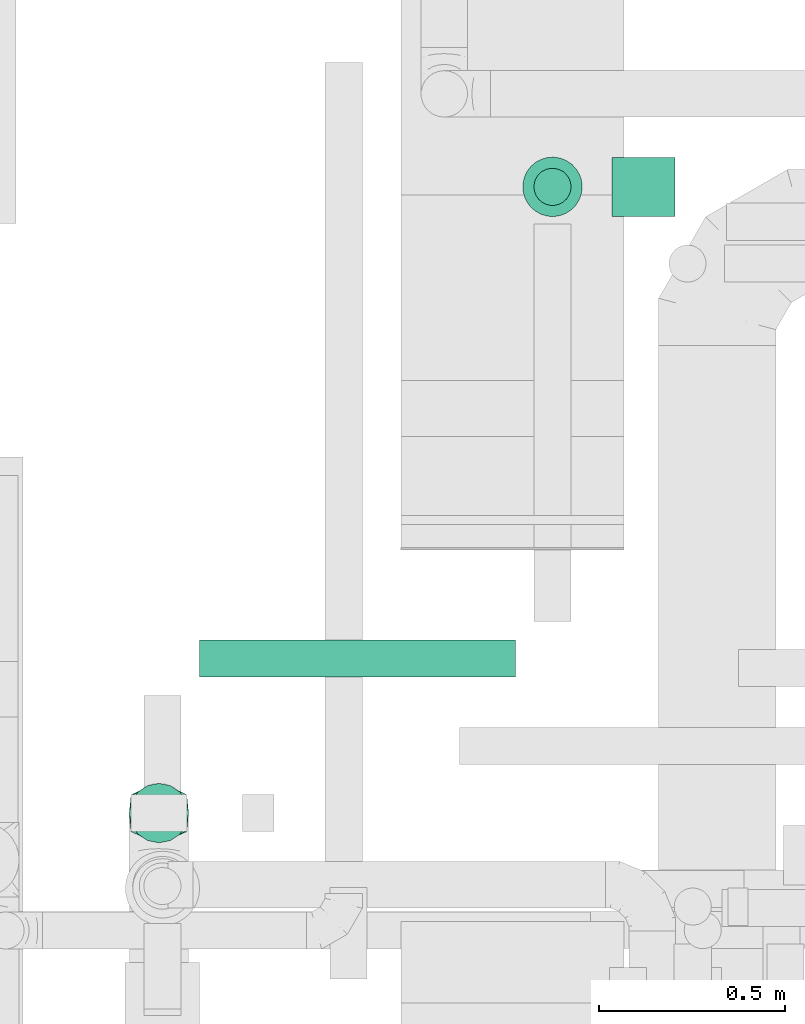
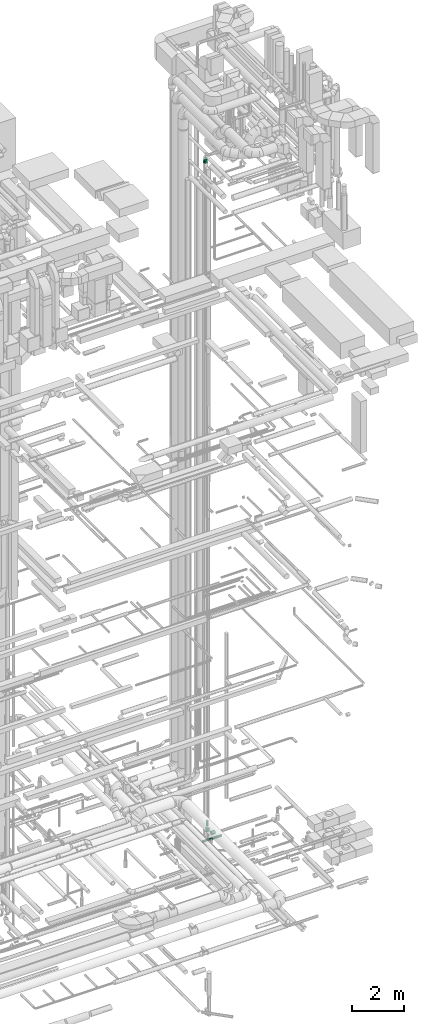
# One storey, part 272 of 337: 4 flow segments, 1 flow fitting.
"""IFC2X3 building model written with IfcOpenShell, lengths in millimetres."""

import ifcopenshell
import ifcopenshell.guid

model = None  # the IFC model being written
_history = None  # IfcOwnerHistory: only IFC2X3 demands one
_inside = {}  # id of a spatial element -> (the spatial element, [elements in it])
_under = {}  # id of a project, library or spatial element -> (it, [spatial elements below it])
_declared = {}  # id of a project -> (the project, [libraries it declares])
_typed = {}  # id of a type object -> (the type object, [elements of that type])
_made_of = {}  # id of a material, layer set ... -> (it, [elements and type objects made of it])


def new_model(schema):
    """Start an empty IFC model of exactly this schema.

    Asked for "IFC4X3", IfcOpenShell would pick the latest addendum, in which some entities
    have other attributes; the version numbers below select the first issue.
    IFC2X3 requires an IfcOwnerHistory on every rooted entity: one is made here for all.
    """
    global model, _history
    if schema == "IFC4X3":
        model = ifcopenshell.file(schema_version=(4, 3, 0, 0))
    else:
        model = ifcopenshell.file(schema=schema)
    _inside.clear()
    _under.clear()
    _declared.clear()
    _typed.clear()
    _made_of.clear()
    _history = None
    if model.schema == "IFC2X3":
        org = make("IfcOrganization", Name="unknown")
        user = make(
            "IfcPersonAndOrganization",
            ThePerson=make("IfcPerson", FamilyName="unknown"),
            TheOrganization=org,
        )
        app = make(
            "IfcApplication",
            ApplicationDeveloper=org,
            Version="unknown",
            ApplicationFullName="unknown",
            ApplicationIdentifier="unknown",
        )
        _history = make(
            "IfcOwnerHistory",
            OwningUser=user,
            OwningApplication=app,
            ChangeAction="ADDED",
            CreationDate=0,
        )
    return model


def make(cls, **values):
    """One entity of the class cls with the attributes given. An attribute that is None is left unset."""
    return model.create_entity(
        cls, **{name: value for name, value in values.items() if value is not None}
    )


def entity(cls, *values):
    """Any entity or typed value of the class cls, its attributes in the order of the schema. None: left unset."""
    e = model.create_entity(cls)
    for i, value in enumerate(values):
        if value is not None:
            e[i] = value
    return e


def rooted(cls, **values):
    """An entity with a GlobalId (a new one), such as an element, a storey or a relation."""
    return make(cls, GlobalId=ifcopenshell.guid.new(), OwnerHistory=_history, **values)


def si_unit(unit_type, name, prefix=None):
    """IfcSIUnit, for example si_unit("LENGTHUNIT", "METRE", prefix="MILLI")."""
    return make("IfcSIUnit", UnitType=unit_type, Prefix=prefix, Name=name)


def converted_unit(unit_type, name, factor, base, dimensions=None, offset=None):
    """IfcConversionBasedUnit, such as the inch: factor (a typed value) times the base unit."""
    return make(
        "IfcConversionBasedUnit"
        if offset is None
        else "IfcConversionBasedUnitWithOffset",
        ConversionOffset=offset,
        Dimensions=None
        if dimensions is None
        else entity("IfcDimensionalExponents", *dimensions),
        UnitType=unit_type,
        Name=name,
        ConversionFactor=make(
            "IfcMeasureWithUnit", ValueComponent=factor, UnitComponent=base
        ),
    )


def derived_unit(unit_type, elements):
    """IfcDerivedUnit: a product of units, each with its exponent."""
    return make(
        "IfcDerivedUnit",
        Elements=[
            make("IfcDerivedUnitElement", Unit=unit, Exponent=power)
            for unit, power in elements
        ],
        UnitType=unit_type,
    )


def assignment(units):
    """IfcUnitAssignment: the units of a project."""
    return None if units is None else make("IfcUnitAssignment", Units=units)


def point(xyz):
    """IfcCartesianPoint."""
    return None if xyz is None else make("IfcCartesianPoint", Coordinates=xyz)


def direction(xyz):
    """IfcDirection."""
    return None if xyz is None else make("IfcDirection", DirectionRatios=xyz)


def frame(location, z_axis=None, x_axis=None):
    """IfcAxis2Placement3D, a coordinate frame: its origin and axes. An axis left out is left unset."""
    return make(
        "IfcAxis2Placement3D",
        Location=point(location),
        Axis=direction(z_axis),
        RefDirection=direction(x_axis),
    )


def frame_2d(location, x_axis=None):
    """IfcAxis2Placement2D, a coordinate frame in the plane: its origin and x axis."""
    return make(
        "IfcAxis2Placement2D", Location=point(location), RefDirection=direction(x_axis)
    )


def origin():
    """The frame at (0, 0, 0) with its axes left unset."""
    return frame((0.0, 0.0, 0.0))


def origin_2d_with_axis():
    """The frame at (0, 0) in the plane with the x axis (1, 0) written out."""
    return frame_2d((0.0, 0.0), x_axis=(1.0, 0.0))


def place(relative_to, where):
    """IfcLocalPlacement: puts the frame where relative to a parent placement (None: the world)."""
    return make(
        "IfcLocalPlacement", PlacementRelTo=relative_to, RelativePlacement=where
    )


def context(
    kind, dimensions, precision=None, world=None, true_north=None, identifier=None
):
    """IfcGeometricRepresentationContext, for example the 3D "Model" context."""
    return make(
        "IfcGeometricRepresentationContext",
        ContextIdentifier=identifier,
        ContextType=kind,
        CoordinateSpaceDimension=dimensions,
        Precision=precision,
        WorldCoordinateSystem=world,
        TrueNorth=true_north,
    )


def subcontext(parent, identifier, kind, view, scale=None):
    """IfcGeometricRepresentationSubContext, for example "Body" below "Model"."""
    return make(
        "IfcGeometricRepresentationSubContext",
        ContextIdentifier=identifier,
        ContextType=kind,
        ParentContext=parent,
        TargetScale=scale,
        TargetView=view,
    )


def project(units=None, contexts=None):
    """IfcProject with its units and contexts."""
    return rooted(
        "IfcProject",
        Name="project",
        RepresentationContexts=contexts,
        UnitsInContext=assignment(units),
    )


def spatial(cls, under=None, at=None, **own):
    """A site, building, storey or space (cls), placed at a placement, below another one or the project."""
    s = rooted(cls, ObjectPlacement=at, **own)
    if under is not None:
        _under.setdefault(under.id(), (under, []))[1].append(s)
    return s


def profile(cls, at=None, kind="AREA", **sizes):
    """A parametric profile (cls). Its sizes go by their IFC names, for example OverallWidth=200.0."""
    return make(cls, ProfileType=kind, Position=at, **sizes)


def circle(**sizes):
    """IfcCircleProfileDef."""
    return profile("IfcCircleProfileDef", **sizes)


def extrude(swept, where, along, depth):
    """IfcExtrudedAreaSolid: the profile swept, set in the frame where, extruded along a direction by depth."""
    return make(
        "IfcExtrudedAreaSolid",
        SweptArea=swept,
        Position=where,
        ExtrudedDirection=direction(along),
        Depth=depth,
    )


def faces_of(points, faces, orient=None, outer=None):
    """IfcFace entities. A face is a list of loops; a loop is a list of indices into points, from 0.

    orient and outer hold one flag for each loop. By default every Orientation is true, the
    first loop of a face is its IfcFaceOuterBound and the others are IfcFaceBound.
    """
    made = []
    for i, loops in enumerate(faces):
        bounds = []
        for j, loop in enumerate(loops):
            is_outer = j == 0 if outer is None else outer[i][j]
            bounds.append(
                make(
                    "IfcFaceOuterBound" if is_outer else "IfcFaceBound",
                    Bound=make("IfcPolyLoop", Polygon=[points[k] for k in loop]),
                    Orientation=True if orient is None else orient[i][j],
                )
            )
        made.append(make("IfcFace", Bounds=bounds))
    return made


def faceted_brep(points, faces, orient=None, outer=None, voids=None):
    """IfcFacetedBrep: a solid bounded by flat faces; with voids (closed shells), ...WithVoids."""
    shared = [point(p) for p in points]
    hull = make("IfcClosedShell", CfsFaces=faces_of(shared, faces, orient, outer))
    if voids is None:
        return make("IfcFacetedBrep", Outer=hull)
    return make(
        "IfcFacetedBrepWithVoids",
        Outer=hull,
        Voids=[
            make(cls, CfsFaces=faces_of(shared, fs, o, b)) for cls, fs, o, b in voids
        ],
    )


def shape(context_of_items, identifier, shape_type, items):
    """IfcShapeRepresentation: the items that make up one representation, for example the "Body"."""
    return make(
        "IfcShapeRepresentation",
        ContextOfItems=context_of_items,
        RepresentationIdentifier=identifier,
        RepresentationType=shape_type,
        Items=items,
    )


def source(mapping_origin, context_of_items, identifier, shape_type, items):
    """IfcRepresentationMap: a shape defined once, which mapped items show again and again."""
    return make(
        "IfcRepresentationMap",
        MappingOrigin=mapping_origin,
        MappedRepresentation=shape(context_of_items, identifier, shape_type, items),
    )


def transform(
    local_origin,
    x_axis=None,
    y_axis=None,
    z_axis=None,
    scale=None,
    scale2=None,
    scale3=None,
    uniform=True,
):
    """IfcCartesianTransformationOperator3D, or its non-uniform kind. x_axis, y_axis, z_axis: its Axis1, 2, 3."""
    if uniform:
        return make(
            "IfcCartesianTransformationOperator3D",
            Axis1=direction(x_axis),
            Axis2=direction(y_axis),
            LocalOrigin=point(local_origin),
            Scale=scale,
            Axis3=direction(z_axis),
        )
    return make(
        "IfcCartesianTransformationOperator3DnonUniform",
        Axis1=direction(x_axis),
        Axis2=direction(y_axis),
        LocalOrigin=point(local_origin),
        Scale=scale,
        Axis3=direction(z_axis),
        Scale2=scale2,
        Scale3=scale3,
    )


def mapped(mapping_source, mapping_target):
    """IfcMappedItem: shows the shape of a source again, moved by a transform."""
    return make(
        "IfcMappedItem", MappingSource=mapping_source, MappingTarget=mapping_target
    )


def material(Name=None, Category=None):
    """IfcMaterial."""
    return make("IfcMaterial", Name=Name, Category=Category)


def made_of(thing, what):
    """Note that an element or type object is made of a material, layer set ...; save() writes the relation."""
    if what is not None:
        _made_of.setdefault(what.id(), (what, []))[1].append(thing)
    return thing


def type_object(cls, material=None, **own):
    """A type object (cls), such as IfcWallType, which elements share."""
    return made_of(rooted(cls, **own), material)


def type_shapes(of_type, sources):
    """Give a type object the sources (RepresentationMaps) that its elements show as mapped items."""
    of_type.RepresentationMaps = sources


def element(
    cls,
    number,
    at=None,
    inside=None,
    cuts=None,
    type_object=None,
    material=None,
    context=None,
    identifier="Body",
    shape_type=None,
    held_by="IfcProductDefinitionShape",
    body=None,
    shapes=None,
    **own,
):
    """One element of the class cls, such as IfcWall. Its Tag is "e" and its number.

    at: its placement. inside: the storey or other place that contains it. cuts: it is an
    opening in that element (IfcRelVoidsElement). A single representation is given by context,
    identifier, shape_type and body (its items); several are given by shapes. held_by: the class
    of the entity that holds the representations. save() writes the other relations.
    """
    e = rooted(cls, Tag="e%d" % number, ObjectPlacement=at, **own)
    if body is not None:
        shapes = [shape(context, identifier, shape_type, body)]
    if shapes is not None:
        e.Representation = make(held_by, Representations=shapes)
    if inside is not None:
        _inside.setdefault(inside.id(), (inside, []))[1].append(e)
    if cuts is not None:
        rooted(
            "IfcRelVoidsElement", RelatingBuildingElement=cuts, RelatedOpeningElement=e
        )
    if type_object is not None:
        _typed.setdefault(type_object.id(), (type_object, []))[1].append(e)
    return made_of(e, material)


def aggregate(whole, parts):
    """IfcRelAggregates: a whole, such as a stair, and the parts it consists of."""
    return rooted("IfcRelAggregates", RelatingObject=whole, RelatedObjects=parts)


def save(model, path):
    """Write the relations noted so far, then the file.

    IfcRelAggregates (storeys below a building ...), IfcRelContainedInSpatialStructure (elements
    in a storey), IfcRelDefinesByType, IfcRelAssociatesMaterial and IfcRelDeclares: one each for
    every whole, place, type object, material and project.
    """
    for whole, parts in _under.values():
        aggregate(whole, parts)
    for where, things in _inside.values():
        rooted(
            "IfcRelContainedInSpatialStructure",
            RelatedElements=things,
            RelatingStructure=where,
        )
    for kind, things in _typed.values():
        rooted("IfcRelDefinesByType", RelatedObjects=things, RelatingType=kind)
    for what, things in _made_of.values():
        rooted("IfcRelAssociatesMaterial", RelatedObjects=things, RelatingMaterial=what)
    for by, libraries in _declared.values():
        rooted("IfcRelDeclares", RelatingContext=by, RelatedDefinitions=libraries)
    model.write(path)


model = new_model("IFC2X3")

# Units and contexts
model_context = context("Model", 3, precision=0.01, world=origin(), true_north=direction((6.12303176911189e-17, 1.0)))
body_context = subcontext(model_context, "Body", "Model", "MODEL_VIEW")
ifc_project = project(units=[si_unit("LENGTHUNIT", "METRE", prefix="MILLI"), si_unit("AREAUNIT", "SQUARE_METRE"), si_unit("VOLUMEUNIT", "CUBIC_METRE"), converted_unit("PLANEANGLEUNIT", "DEGREE", entity("IfcRatioMeasure", 0.0174532925199433), si_unit("PLANEANGLEUNIT", "RADIAN"), dimensions=[0, 0, 0, 0, 0, 0, 0]), si_unit("MASSUNIT", "GRAM", prefix="KILO"), derived_unit("MASSDENSITYUNIT", [(si_unit("MASSUNIT", "GRAM", prefix="KILO"), 1), (si_unit("LENGTHUNIT", "METRE"), -3)]), derived_unit("MOMENTOFINERTIAUNIT", [(si_unit("LENGTHUNIT", "METRE"), 4)]), si_unit("TIMEUNIT", "SECOND"), si_unit("FREQUENCYUNIT", "HERTZ"), si_unit("THERMODYNAMICTEMPERATUREUNIT", "DEGREE_CELSIUS"), derived_unit("THERMALTRANSMITTANCEUNIT", [(si_unit("MASSUNIT", "GRAM", prefix="KILO"), 1), (si_unit("THERMODYNAMICTEMPERATUREUNIT", "KELVIN"), -1), (si_unit("TIMEUNIT", "SECOND"), -3)]), derived_unit("VOLUMETRICFLOWRATEUNIT", [(si_unit("LENGTHUNIT", "METRE"), 3), (si_unit("TIMEUNIT", "SECOND"), -1)]), derived_unit("MASSFLOWRATEUNIT", [(si_unit("MASSUNIT", "GRAM", prefix="KILO"), 1), (si_unit("TIMEUNIT", "SECOND"), -1)]), derived_unit("ROTATIONALFREQUENCYUNIT", [(si_unit("TIMEUNIT", "SECOND"), -1)]), si_unit("ELECTRICCURRENTUNIT", "AMPERE"), si_unit("ELECTRICVOLTAGEUNIT", "VOLT"), si_unit("POWERUNIT", "WATT"), si_unit("FORCEUNIT", "NEWTON", prefix="KILO"), si_unit("ILLUMINANCEUNIT", "LUX"), si_unit("LUMINOUSFLUXUNIT", "LUMEN"), si_unit("LUMINOUSINTENSITYUNIT", "CANDELA"), derived_unit("USERDEFINED", [(si_unit("MASSUNIT", "GRAM", prefix="KILO"), -1), (si_unit("LENGTHUNIT", "METRE"), -2), (si_unit("TIMEUNIT", "SECOND"), 3), (si_unit("LUMINOUSFLUXUNIT", "LUMEN"), 1)]), derived_unit("LINEARVELOCITYUNIT", [(si_unit("LENGTHUNIT", "METRE"), 1), (si_unit("TIMEUNIT", "SECOND"), -1)]), si_unit("PRESSUREUNIT", "PASCAL"), derived_unit("USERDEFINED", [(si_unit("LENGTHUNIT", "METRE"), -2), (si_unit("MASSUNIT", "GRAM", prefix="KILO"), 1), (si_unit("TIMEUNIT", "SECOND"), -2)]), derived_unit("LINEARFORCEUNIT", [(si_unit("MASSUNIT", "GRAM", prefix="KILO"), 1), (si_unit("LENGTHUNIT", "METRE"), 1), (si_unit("TIMEUNIT", "SECOND"), -2), (si_unit("LENGTHUNIT", "METRE"), -1)]), derived_unit("PLANARFORCEUNIT", [(si_unit("MASSUNIT", "GRAM", prefix="KILO"), 1), (si_unit("LENGTHUNIT", "METRE"), 1), (si_unit("TIMEUNIT", "SECOND"), -2), (si_unit("LENGTHUNIT", "METRE"), -2)])], contexts=[model_context])

# Site, building, storey
site_placement = place(None, origin())
site = spatial("IfcSite", under=ifc_project, at=site_placement, CompositionType="ELEMENT")
building_placement = place(site_placement, origin())
building = spatial("IfcBuilding", under=site, at=building_placement, CompositionType="ELEMENT")
storey_placement = place(building_placement, origin())
storey = spatial("IfcBuildingStorey", under=building, at=storey_placement, CompositionType="ELEMENT", Elevation=0.0)

# Flow segments
duct_segment_type = type_object("IfcDuctSegmentType", PredefinedType="NOTDEFINED")
flow_segment_1_placement = place(storey_placement, frame((68713.63, 12234.34, -951.6)))
element("IfcFlowSegment", 1, at=flow_segment_1_placement, inside=storey, type_object=duct_segment_type, context=body_context, shape_type="SweptSolid", body=[
    extrude(circle(Radius=50.0, at=origin_2d_with_axis()), frame((0.0, 51.6, 51.6), z_axis=(1.0, 0.0, 0.0), x_axis=(0.0, -1.0, 0.0)), (0.0, 0.0, 1.0), 849.405366964998),
])
flow_segment_2_placement = place(storey_placement, frame((69611.44, 13503.37, -1243.99)))
element("IfcFlowSegment", 2, at=flow_segment_2_placement, inside=storey, type_object=duct_segment_type, context=body_context, shape_type="SweptSolid", body=[
    extrude(circle(Radius=50.0, at=origin_2d_with_axis()), frame((51.6, 51.6, 0.0), z_axis=(0.0, 0.0, 1.0), x_axis=(-1.0, 0.0, 0.0)), (0.0, 0.0, 1.0), 243.991104750007),
])
flow_segment_3_placement = place(storey_placement, frame((69581.44, 13473.37, -1493.0)))
element("IfcFlowSegment", 3, at=flow_segment_3_placement, inside=storey, type_object=duct_segment_type, context=body_context, shape_type="SweptSolid", body=[
    extrude(circle(Radius=80.0, at=origin_2d_with_axis()), frame((81.6, 81.6, 0.0)), (0.0, 0.0, 1.0), 137.008895249999),
])
flow_segment_4_placement = place(storey_placement, frame((69823.03, 13473.37, -1734.6)))
element("IfcFlowSegment", 4, at=flow_segment_4_placement, inside=storey, type_object=duct_segment_type, context=body_context, shape_type="SweptSolid", body=[
    extrude(circle(Radius=80.0, at=origin_2d_with_axis()), frame((0.0, 81.6, 81.6), z_axis=(1.0, 0.0, 0.0), x_axis=(0.0, -1.0, 0.0)), (0.0, 0.0, 1.0), 170.000000000013),
])

# Flow fitting
ifc_material = material()
duct_fitting_type = type_object("IfcDuctFittingType", PredefinedType="NOTDEFINED", material=ifc_material)
shared_shape = source(origin(), body_context, "Body", "Brep", [
    faceted_brep([(200.0, 30.61, 73.91), (200.0, 22.87, 75.45), (200.0, 15.12, 76.99), (200.0, 11.34, 77.74), (200.0, 7.56, 78.5), (200.0, 0.0, 80.0), (200.0, -7.56, 78.5), (200.0, -15.12, 76.99), (200.0, -18.99, 76.22), (200.0, -22.87, 75.45), (200.0, -30.61, 73.91), (200.0, -37.1, 69.57), (200.0, -43.59, 65.24), (200.0, -50.08, 60.9), (200.0, -56.57, 56.57), (200.0, -60.9, 50.08), (200.0, -65.24, 43.59), (200.0, -69.57, 37.1), (200.0, -73.91, 30.61), (200.0, -75.45, 22.87), (200.0, -76.99, 15.12), (200.0, -77.74, 11.34), (200.0, -78.5, 7.56), (200.0, -80.0, 0.0), (200.0, -78.5, -7.56), (200.0, -76.99, -15.12), (200.0, -76.22, -18.99), (200.0, -75.45, -22.87), (200.0, -73.91, -30.61), (200.0, -69.57, -37.1), (200.0, -65.24, -43.59), (200.0, -60.9, -50.08), (200.0, -56.57, -56.57), (200.0, -50.08, -60.9), (200.0, -43.59, -65.24), (200.0, -37.1, -69.57), (200.0, -30.61, -73.91), (200.0, -22.87, -75.45), (200.0, -15.12, -76.99), (200.0, -11.34, -77.74), (200.0, -7.56, -78.5), (200.0, 0.0, -80.0), (200.0, 7.56, -78.5), (200.0, 15.12, -76.99), (200.0, 18.99, -76.22), (200.0, 22.87, -75.45), (200.0, 30.61, -73.91), (200.0, 37.1, -69.57), (200.0, 43.59, -65.24), (200.0, 50.08, -60.9), (200.0, 56.57, -56.57), (200.0, 60.9, -50.08), (200.0, 65.24, -43.59), (200.0, 69.57, -37.1), (200.0, 73.91, -30.61), (200.0, 75.45, -22.87), (200.0, 76.99, -15.12), (200.0, 77.74, -11.34), (200.0, 78.5, -7.56), (200.0, 80.0, 0.0), (200.0, 78.5, 7.56), (200.0, 76.99, 15.12), (200.0, 76.22, 18.99), (200.0, 75.45, 22.87), (200.0, 73.91, 30.61), (200.0, 69.57, 37.1), (200.0, 65.24, 43.59), (200.0, 60.9, 50.08), (200.0, 56.57, 56.57), (200.0, 50.08, 60.9), (200.0, 43.59, 65.24), (200.0, 37.1, 69.57), (0.0, -50.0, 75.0), (0.0, 50.0, 75.0), (0.0, 50.0, -75.0), (0.0, -50.0, -75.0), (52.06, -36.99, 76.3), (78.09, -30.48, 76.95), (176.03, -5.99, 79.4), (152.06, -11.99, 78.8), (128.09, -17.98, 78.2), (104.11, -23.97, 77.6), (100.0, -54.94, 64.02), (78.09, -61.71, 45.72), (104.11, -65.62, 35.96), (128.09, -69.21, 26.97), (152.06, -72.81, 17.98), (164.04, -74.61, 13.48), (176.03, -76.4, 8.99), (26.03, -53.9, 65.24), (52.06, -57.81, 55.48), (26.03, -43.49, 75.65), (26.03, -53.9, -65.24), (52.06, -57.81, -55.48), (78.09, -61.71, -45.72), (104.11, -65.62, -35.96), (128.09, -69.21, -26.97), (152.06, -72.81, -17.98), (176.03, -76.4, -8.99), (100.0, -51.52, -67.44), (78.09, -30.48, -76.95), (104.11, -23.97, -77.6), (128.09, -17.98, -78.2), (152.06, -11.99, -78.8), (164.04, -8.99, -79.1), (176.03, -5.99, -79.4), (26.03, -43.49, -75.65), (52.06, -36.99, -76.3), (26.03, 43.49, -75.65), (52.06, 36.99, -76.3), (78.09, 30.48, -76.95), (104.11, 23.97, -77.6), (128.09, 17.98, -78.2), (152.06, 11.99, -78.8), (176.03, 5.99, -79.4), (100.0, 54.94, -64.02), (78.09, 61.71, -45.72), (104.11, 65.62, -35.96), (128.09, 69.21, -26.97), (152.06, 72.81, -17.98), (164.04, 74.61, -13.48), (176.03, 76.4, -8.99), (26.03, 53.9, -65.24), (52.06, 57.81, -55.48), (26.03, 53.9, 65.24), (52.06, 57.81, 55.48), (78.09, 61.71, 45.72), (104.11, 65.62, 35.96), (128.09, 69.21, 26.97), (152.06, 72.81, 17.98), (176.03, 76.4, 8.99), (100.0, 51.52, 67.44), (78.09, 30.48, 76.95), (104.11, 23.97, 77.6), (128.09, 17.98, 78.2), (152.06, 11.99, 78.8), (164.04, 8.99, 79.1), (176.03, 5.99, 79.4), (26.03, 43.49, 75.65), (52.06, 36.99, 76.3)], [[[0, 1, 2, 3, 4, 5, 6, 7, 8, 9, 10, 11, 12, 13, 14, 15, 16, 17, 18, 19, 20, 21, 22, 23, 24, 25, 26, 27, 28, 29, 30, 31, 32, 33, 34, 35, 36, 37, 38, 39, 40, 41, 42, 43, 44, 45, 46, 47, 48, 49, 50, 51, 52, 53, 54, 55, 56, 57, 58, 59, 60, 61, 62, 63, 64, 65, 66, 67, 68, 69, 70, 71]], [[72, 73, 74, 75]], [[76, 12, 77]], [[12, 11, 10, 77]], [[78, 79, 80, 81, 77, 10, 9, 8, 7, 6, 5]], [[13, 82, 14]], [[20, 19, 18, 83, 84, 85, 86, 87, 88, 23, 22, 21]], [[82, 72, 89]], [[82, 15, 14]], [[83, 16, 90]], [[91, 72, 82]], [[18, 17, 16, 83]], [[90, 16, 15]], [[15, 82, 89]], [[90, 15, 89]], [[76, 13, 12]], [[13, 76, 91]], [[82, 13, 91]], [[88, 87, 86, 85, 84, 83, 90, 89, 72, 75, 92, 93, 94, 95, 96, 97, 98, 23]], [[93, 30, 94]], [[30, 29, 28, 94]], [[98, 97, 96, 95, 94, 28, 27, 26, 25, 24, 23]], [[31, 99, 32]], [[38, 37, 36, 100, 101, 102, 103, 104, 105, 41, 40, 39]], [[99, 75, 106]], [[99, 33, 32]], [[100, 34, 107]], [[92, 75, 99]], [[36, 35, 34, 100]], [[107, 34, 33]], [[33, 99, 106]], [[107, 33, 106]], [[93, 31, 30]], [[31, 93, 92]], [[99, 31, 92]], [[105, 104, 103, 102, 101, 100, 107, 106, 75, 74, 108, 109, 110, 111, 112, 113, 114, 41]], [[109, 48, 110]], [[48, 47, 46, 110]], [[114, 113, 112, 111, 110, 46, 45, 44, 43, 42, 41]], [[49, 115, 50]], [[56, 55, 54, 116, 117, 118, 119, 120, 121, 59, 58, 57]], [[115, 74, 122]], [[115, 51, 50]], [[116, 52, 123]], [[108, 74, 115]], [[54, 53, 52, 116]], [[123, 52, 51]], [[51, 115, 122]], [[123, 51, 122]], [[109, 49, 48]], [[49, 109, 108]], [[115, 49, 108]], [[74, 73, 124, 125, 126, 127, 128, 129, 130, 59, 121, 120, 119, 118, 117, 116, 123, 122]], [[125, 66, 126]], [[66, 65, 64, 126]], [[130, 129, 128, 127, 126, 64, 63, 62, 61, 60, 59]], [[67, 131, 68]], [[2, 1, 0, 132, 133, 134, 135, 136, 137, 5, 4, 3]], [[131, 73, 138]], [[131, 69, 68]], [[132, 70, 139]], [[124, 73, 131]], [[0, 71, 70, 132]], [[139, 70, 69]], [[69, 131, 138]], [[139, 69, 138]], [[125, 67, 66]], [[67, 125, 124]], [[131, 67, 124]], [[73, 72, 91, 76, 77, 81, 80, 79, 78, 5, 137, 136, 135, 134, 133, 132, 139, 138]]]),
])
type_shapes(duct_fitting_type, [shared_shape])
flow_fitting_placement = place(storey_placement, frame((68604.23, 11870.03, 31540.0), z_axis=(-1.0, 0.0, 0.0), x_axis=(0.0, 0.0, 1.0)))
element("IfcFlowFitting", 5, at=flow_fitting_placement, inside=storey, type_object=duct_fitting_type, material=ifc_material, context=body_context, shape_type="MappedRepresentation", body=[
    mapped(shared_shape, transform((0.0, 0.0, 0.0), scale=1.0)),
])

save(model, "model.ifc")
